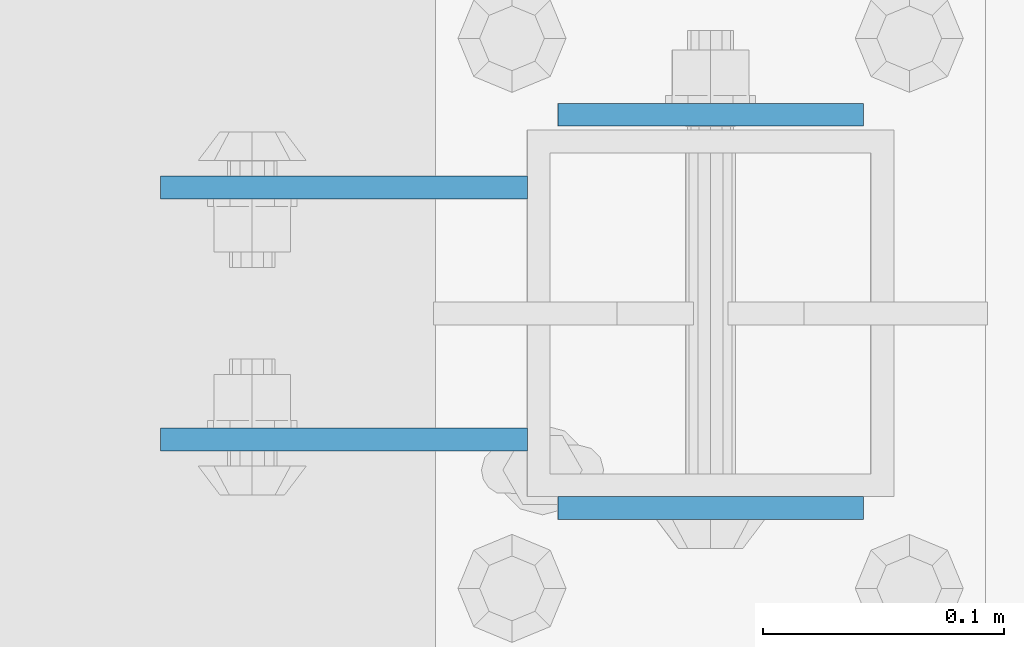
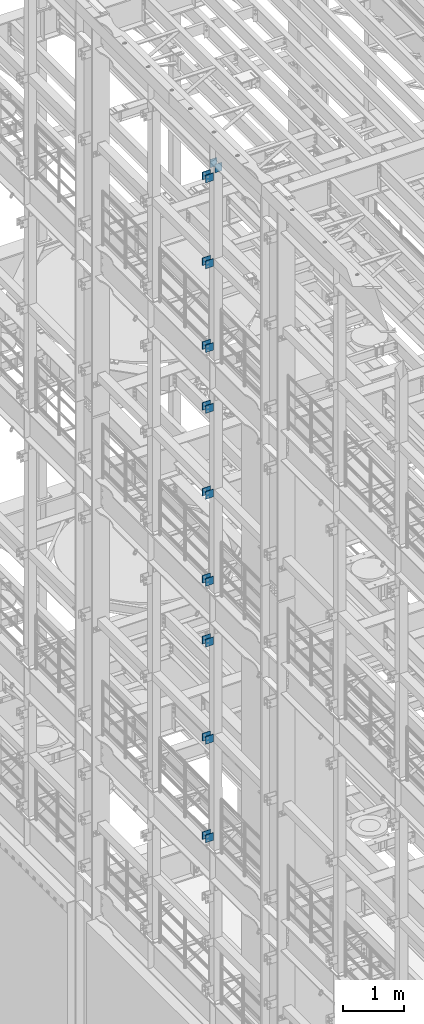
# One storey, part 1248 of 1876: 20 beams, 4 elements without a shape of their own.
"""IFC2X3 building model written with IfcOpenShell, lengths in millimetres."""

from ifc_helpers import new_model, si_unit, frame, origin_with_axes, place, context, subcontext, project, spatial, faceted_brep, material, type_object, element, aggregate, save


model = new_model("IFC2X3")

# Units and contexts
model_context = context("Model", 3, precision=1e-05, world=origin_with_axes())
body_context = subcontext(model_context, "Body", "Model", "MODEL_VIEW")
ifc_project = project(units=[si_unit("LENGTHUNIT", "METRE", prefix="MILLI"), si_unit("AREAUNIT", "SQUARE_METRE"), si_unit("VOLUMEUNIT", "CUBIC_METRE"), si_unit("MASSUNIT", "GRAM", prefix="KILO"), si_unit("TIMEUNIT", "SECOND"), si_unit("PLANEANGLEUNIT", "RADIAN"), si_unit("SOLIDANGLEUNIT", "STERADIAN"), si_unit("THERMODYNAMICTEMPERATUREUNIT", "DEGREE_CELSIUS"), si_unit("LUMINOUSINTENSITYUNIT", "LUMEN")], contexts=[model_context])

# Site, building, storey
site_placement = place(None, origin_with_axes())
site = spatial("IfcSite", under=ifc_project, at=site_placement, CompositionType="ELEMENT")
building_placement = place(site_placement, origin_with_axes())
building = spatial("IfcBuilding", under=site, at=building_placement, Name="Undefined", CompositionType="ELEMENT")
storey_placement = place(building_placement, origin_with_axes())
storey = spatial("IfcBuildingStorey", under=building, at=storey_placement, Name="Undefined", CompositionType="ELEMENT", Elevation=0.0)

# Assembly, beams
assembly_1_placement = place(storey_placement, origin_with_axes())
assembly_1 = element("IfcElementAssembly", 1, at=assembly_1_placement, inside=storey, Name="BEAM", AssemblyPlace="NOTDEFINED", PredefinedType="RIGID_FRAME")
ifc_material = material(Name="STEEL/A36")
beam_type_1 = type_object("IfcBeamType", PredefinedType="NOTDEFINED")
beam_1_placement = place(assembly_1_placement, frame((-76.2000002548894, 3608.3875, 18275.3), z_axis=(0.0, 0.0, -1.0), x_axis=(-1.0, 0.0, 0.0)))
beam_1 = element("IfcBeam", 2, at=beam_1_placement, type_object=beam_type_1, material=ifc_material, Name="PLATE", context=body_context, shape_type="Brep", body=[
    faceted_brep([(0.0, 4.76249999999982, -76.1999999999998), (3.63797880709171e-12, 4.76249999999982, 76.1999969482422), (152.399993896484, 4.76250000000073, 76.1999969482422), (152.4, 4.76249999999982, -76.1999999999998), (3.63797880709171e-12, -4.76249999999982, 76.1999969482422), (152.399993896484, -4.76250000000073, 76.1999969482422), (0.0, -4.76249999999982, -76.1999999999998), (152.4, -4.76249999999982, -76.1999999999998)], [[[0, 1, 2, 3]], [[4, 5, 2, 1]], [[4, 6, 7, 5]], [[6, 0, 3, 7]], [[5, 7, 3, 2]], [[6, 4, 1, 0]]]),
])
beam_2_placement = place(assembly_1_placement, frame((-76.2000002548894, 3503.6125, 18275.3), z_axis=(0.0, 0.0, -1.0), x_axis=(-1.0, 0.0, 0.0)))
beam_2 = element("IfcBeam", 3, at=beam_2_placement, type_object=beam_type_1, material=ifc_material, Name="PLATE", context=body_context, shape_type="Brep", body=[
    faceted_brep([(0.0, 4.76249999999982, -76.1999999999998), (3.63797880709171e-12, 4.76249999999982, 76.1999969482422), (152.399993896484, 4.76250000000073, 76.1999969482422), (152.4, 4.76249999999982, -76.1999999999998), (3.63797880709171e-12, -4.76249999999982, 76.1999969482422), (152.399993896484, -4.76250000000073, 76.1999969482422), (0.0, -4.76249999999982, -76.1999999999998), (152.4, -4.76249999999982, -76.1999999999998)], [[[0, 1, 2, 3]], [[4, 5, 2, 1]], [[4, 6, 7, 5]], [[6, 0, 3, 7]], [[5, 7, 3, 2]], [[6, 4, 1, 0]]]),
])
beam_3_placement = place(assembly_1_placement, frame((-76.2000002548895, 3608.3875, 21678.9), z_axis=(0.0, 0.0, -1.0), x_axis=(-1.0, 0.0, 0.0)))
beam_3 = element("IfcBeam", 4, at=beam_3_placement, type_object=beam_type_1, material=ifc_material, Name="PLATE", context=body_context, shape_type="Brep", body=[
    faceted_brep([(0.0, 4.76249999999982, -76.1999999999998), (3.63797880709171e-12, 4.76249999999982, 76.1999969482422), (152.399993896484, 4.76250000000073, 76.1999969482422), (152.4, 4.76249999999982, -76.1999999999998), (3.63797880709171e-12, -4.76249999999982, 76.1999969482422), (152.399993896484, -4.76250000000073, 76.1999969482422), (0.0, -4.76249999999982, -76.1999999999998), (152.4, -4.76249999999982, -76.1999999999998)], [[[0, 1, 2, 3]], [[4, 5, 2, 1]], [[4, 6, 7, 5]], [[6, 0, 3, 7]], [[5, 7, 3, 2]], [[6, 4, 1, 0]]]),
])
beam_4_placement = place(assembly_1_placement, frame((-76.2000002548895, 3503.6125, 21678.9), z_axis=(0.0, 0.0, -1.0), x_axis=(-1.0, 0.0, 0.0)))
beam_4 = element("IfcBeam", 5, at=beam_4_placement, type_object=beam_type_1, material=ifc_material, Name="PLATE", context=body_context, shape_type="Brep", body=[
    faceted_brep([(0.0, 4.76249999999982, -76.1999999999998), (3.63797880709171e-12, 4.76249999999982, 76.1999969482422), (152.399993896484, 4.76250000000073, 76.1999969482422), (152.4, 4.76249999999982, -76.1999999999998), (3.63797880709171e-12, -4.76249999999982, 76.1999969482422), (152.399993896484, -4.76250000000073, 76.1999969482422), (0.0, -4.76249999999982, -76.1999999999998), (152.4, -4.76249999999982, -76.1999999999998)], [[[0, 1, 2, 3]], [[4, 5, 2, 1]], [[4, 6, 7, 5]], [[6, 0, 3, 7]], [[5, 7, 3, 2]], [[6, 4, 1, 0]]]),
])
beam_5_placement = place(assembly_1_placement, frame((-76.2000002548895, 3608.3875, 19958.05), z_axis=(0.0, 0.0, -1.0), x_axis=(-1.0, 0.0, 0.0)))
beam_5 = element("IfcBeam", 6, at=beam_5_placement, type_object=beam_type_1, material=ifc_material, Name="PLATE", context=body_context, shape_type="Brep", body=[
    faceted_brep([(0.0, 4.76249999999982, -76.1999999999998), (3.63797880709171e-12, 4.76249999999982, 76.1999969482422), (152.399993896484, 4.76250000000073, 76.1999969482422), (152.4, 4.76249999999982, -76.1999999999998), (3.63797880709171e-12, -4.76249999999982, 76.1999969482422), (152.399993896484, -4.76250000000073, 76.1999969482422), (0.0, -4.76249999999982, -76.1999999999998), (152.4, -4.76249999999982, -76.1999999999998)], [[[0, 1, 2, 3]], [[4, 5, 2, 1]], [[4, 6, 7, 5]], [[6, 0, 3, 7]], [[5, 7, 3, 2]], [[6, 4, 1, 0]]]),
])
beam_6_placement = place(assembly_1_placement, frame((-76.2000002548895, 3503.6125, 19958.05), z_axis=(0.0, 0.0, -1.0), x_axis=(-1.0, 0.0, 0.0)))
beam_6 = element("IfcBeam", 7, at=beam_6_placement, type_object=beam_type_1, material=ifc_material, Name="PLATE", context=body_context, shape_type="Brep", body=[
    faceted_brep([(0.0, 4.76249999999982, -76.1999999999998), (3.63797880709171e-12, 4.76249999999982, 76.1999969482422), (152.399993896484, 4.76250000000073, 76.1999969482422), (152.4, 4.76249999999982, -76.1999999999998), (3.63797880709171e-12, -4.76249999999982, 76.1999969482422), (152.399993896484, -4.76250000000073, 76.1999969482422), (0.0, -4.76249999999982, -76.1999999999998), (152.4, -4.76249999999982, -76.1999999999998)], [[[0, 1, 2, 3]], [[4, 5, 2, 1]], [[4, 6, 7, 5]], [[6, 0, 3, 7]], [[5, 7, 3, 2]], [[6, 4, 1, 0]]]),
])
aggregate(assembly_1, [beam_1, beam_2, beam_3, beam_4, beam_5, beam_6])

assembly_2_placement = place(storey_placement, origin_with_axes())
assembly_2 = element("IfcElementAssembly", 8, at=assembly_2_placement, inside=storey, Name="BEAM", AssemblyPlace="NOTDEFINED", PredefinedType="RIGID_FRAME")
beam_7_placement = place(assembly_2_placement, frame((-76.1999999999999, 3608.3875, 13589.0), z_axis=(0.0, 0.0, -1.0), x_axis=(-1.0, 0.0, 0.0)))
beam_7 = element("IfcBeam", 9, at=beam_7_placement, type_object=beam_type_1, material=ifc_material, Name="PLATE", context=body_context, shape_type="Brep", body=[
    faceted_brep([(0.0, 4.76249999999982, -76.1999999999998), (3.63797880709171e-12, 4.76249999999982, 76.1999969482422), (152.399993896484, 4.76250000000073, 76.1999969482422), (152.4, 4.76249999999982, -76.1999999999998), (3.63797880709171e-12, -4.76249999999982, 76.1999969482422), (152.399993896484, -4.76250000000073, 76.1999969482422), (0.0, -4.76249999999982, -76.1999999999998), (152.4, -4.76249999999982, -76.1999999999998)], [[[0, 1, 2, 3]], [[4, 5, 2, 1]], [[4, 6, 7, 5]], [[6, 0, 3, 7]], [[5, 7, 3, 2]], [[6, 4, 1, 0]]]),
])
beam_8_placement = place(assembly_2_placement, frame((-76.1999999999999, 3503.6125, 13589.0), z_axis=(0.0, 0.0, -1.0), x_axis=(-1.0, 0.0, 0.0)))
beam_8 = element("IfcBeam", 10, at=beam_8_placement, type_object=beam_type_1, material=ifc_material, Name="PLATE", context=body_context, shape_type="Brep", body=[
    faceted_brep([(0.0, 4.76249999999982, -76.1999999999998), (3.63797880709171e-12, 4.76249999999982, 76.1999969482422), (152.399993896484, 4.76250000000073, 76.1999969482422), (152.4, 4.76249999999982, -76.1999999999998), (3.63797880709171e-12, -4.76249999999982, 76.1999969482422), (152.399993896484, -4.76250000000073, 76.1999969482422), (0.0, -4.76249999999982, -76.1999999999998), (152.4, -4.76249999999982, -76.1999999999998)], [[[0, 1, 2, 3]], [[4, 5, 2, 1]], [[4, 6, 7, 5]], [[6, 0, 3, 7]], [[5, 7, 3, 2]], [[6, 4, 1, 0]]]),
])
beam_9_placement = place(assembly_2_placement, frame((-76.2, 3608.3875, 17056.1), z_axis=(0.0, 0.0, -1.0), x_axis=(-1.0, 0.0, 0.0)))
beam_9 = element("IfcBeam", 11, at=beam_9_placement, type_object=beam_type_1, material=ifc_material, Name="PLATE", context=body_context, shape_type="Brep", body=[
    faceted_brep([(0.0, 4.76249999999982, -76.1999999999998), (3.63797880709171e-12, 4.76249999999982, 76.1999969482422), (152.399993896484, 4.76250000000073, 76.1999969482422), (152.4, 4.76249999999982, -76.1999999999998), (3.63797880709171e-12, -4.76249999999982, 76.1999969482422), (152.399993896484, -4.76250000000073, 76.1999969482422), (0.0, -4.76249999999982, -76.1999999999998), (152.4, -4.76249999999982, -76.1999999999998)], [[[0, 1, 2, 3]], [[4, 5, 2, 1]], [[4, 6, 7, 5]], [[6, 0, 3, 7]], [[5, 7, 3, 2]], [[6, 4, 1, 0]]]),
])
beam_10_placement = place(assembly_2_placement, frame((-76.2, 3503.6125, 17056.1), z_axis=(0.0, 0.0, -1.0), x_axis=(-1.0, 0.0, 0.0)))
beam_10 = element("IfcBeam", 12, at=beam_10_placement, type_object=beam_type_1, material=ifc_material, Name="PLATE", context=body_context, shape_type="Brep", body=[
    faceted_brep([(0.0, 4.76249999999982, -76.1999999999998), (3.63797880709171e-12, 4.76249999999982, 76.1999969482422), (152.399993896484, 4.76250000000073, 76.1999969482422), (152.4, 4.76249999999982, -76.1999999999998), (3.63797880709171e-12, -4.76249999999982, 76.1999969482422), (152.399993896484, -4.76250000000073, 76.1999969482422), (0.0, -4.76249999999982, -76.1999999999998), (152.4, -4.76249999999982, -76.1999999999998)], [[[0, 1, 2, 3]], [[4, 5, 2, 1]], [[4, 6, 7, 5]], [[6, 0, 3, 7]], [[5, 7, 3, 2]], [[6, 4, 1, 0]]]),
])
beam_11_placement = place(assembly_2_placement, frame((-76.2, 3608.3875, 15335.25), z_axis=(0.0, 0.0, -1.0), x_axis=(-1.0, 0.0, 0.0)))
beam_11 = element("IfcBeam", 13, at=beam_11_placement, type_object=beam_type_1, material=ifc_material, Name="PLATE", context=body_context, shape_type="Brep", body=[
    faceted_brep([(0.0, 4.76249999999982, -76.1999999999998), (3.63797880709171e-12, 4.76249999999982, 76.1999969482422), (152.399993896484, 4.76250000000073, 76.1999969482422), (152.4, 4.76249999999982, -76.1999999999998), (3.63797880709171e-12, -4.76249999999982, 76.1999969482422), (152.399993896484, -4.76250000000073, 76.1999969482422), (0.0, -4.76249999999982, -76.1999999999998), (152.4, -4.76249999999982, -76.1999999999998)], [[[0, 1, 2, 3]], [[4, 5, 2, 1]], [[4, 6, 7, 5]], [[6, 0, 3, 7]], [[5, 7, 3, 2]], [[6, 4, 1, 0]]]),
])
beam_12_placement = place(assembly_2_placement, frame((-76.2, 3503.6125, 15335.25), z_axis=(0.0, 0.0, -1.0), x_axis=(-1.0, 0.0, 0.0)))
beam_12 = element("IfcBeam", 14, at=beam_12_placement, type_object=beam_type_1, material=ifc_material, Name="PLATE", context=body_context, shape_type="Brep", body=[
    faceted_brep([(0.0, 4.76249999999982, -76.1999999999998), (3.63797880709171e-12, 4.76249999999982, 76.1999969482422), (152.399993896484, 4.76250000000073, 76.1999969482422), (152.4, 4.76249999999982, -76.1999999999998), (3.63797880709171e-12, -4.76249999999982, 76.1999969482422), (152.399993896484, -4.76250000000073, 76.1999969482422), (0.0, -4.76249999999982, -76.1999999999998), (152.4, -4.76249999999982, -76.1999999999998)], [[[0, 1, 2, 3]], [[4, 5, 2, 1]], [[4, 6, 7, 5]], [[6, 0, 3, 7]], [[5, 7, 3, 2]], [[6, 4, 1, 0]]]),
])
aggregate(assembly_2, [beam_7, beam_8, beam_9, beam_10, beam_11, beam_12])

assembly_3_placement = place(storey_placement, origin_with_axes())
assembly_3 = element("IfcElementAssembly", 15, at=assembly_3_placement, inside=storey, Name="BEAM", AssemblyPlace="NOTDEFINED", PredefinedType="RIGID_FRAME")
beam_13_placement = place(assembly_3_placement, frame((-76.1999999999999, 3608.3875, 12369.8), z_axis=(0.0, 0.0, -1.0), x_axis=(-1.0, 0.0, 0.0)))
beam_13 = element("IfcBeam", 16, at=beam_13_placement, type_object=beam_type_1, material=ifc_material, Name="PLATE", context=body_context, shape_type="Brep", body=[
    faceted_brep([(0.0, 4.76249999999982, -76.1999999999998), (3.63797880709171e-12, 4.76249999999982, 76.1999969482422), (152.399993896484, 4.76250000000073, 76.1999969482422), (152.4, 4.76249999999982, -76.1999999999998), (3.63797880709171e-12, -4.76249999999982, 76.1999969482422), (152.399993896484, -4.76250000000073, 76.1999969482422), (0.0, -4.76249999999982, -76.1999999999998), (152.4, -4.76249999999982, -76.1999999999998)], [[[0, 1, 2, 3]], [[4, 5, 2, 1]], [[4, 6, 7, 5]], [[6, 0, 3, 7]], [[5, 7, 3, 2]], [[6, 4, 1, 0]]]),
])
beam_14_placement = place(assembly_3_placement, frame((-76.1999999999999, 3503.6125, 12369.8), z_axis=(0.0, 0.0, -1.0), x_axis=(-1.0, 0.0, 0.0)))
beam_14 = element("IfcBeam", 17, at=beam_14_placement, type_object=beam_type_1, material=ifc_material, Name="PLATE", context=body_context, shape_type="Brep", body=[
    faceted_brep([(0.0, 4.76249999999982, -76.1999999999998), (3.63797880709171e-12, 4.76249999999982, 76.1999969482422), (152.399993896484, 4.76250000000073, 76.1999969482422), (152.4, 4.76249999999982, -76.1999999999998), (3.63797880709171e-12, -4.76249999999982, 76.1999969482422), (152.399993896484, -4.76250000000073, 76.1999969482422), (0.0, -4.76249999999982, -76.1999999999998), (152.4, -4.76249999999982, -76.1999999999998)], [[[0, 1, 2, 3]], [[4, 5, 2, 1]], [[4, 6, 7, 5]], [[6, 0, 3, 7]], [[5, 7, 3, 2]], [[6, 4, 1, 0]]]),
])
beam_15_placement = place(assembly_3_placement, frame((-76.2, 3608.3875, 8445.5), z_axis=(0.0, 0.0, -1.0), x_axis=(-1.0, 0.0, 0.0)))
beam_15 = element("IfcBeam", 18, at=beam_15_placement, type_object=beam_type_1, material=ifc_material, Name="PLATE", context=body_context, shape_type="Brep", body=[
    faceted_brep([(0.0, 4.76249999999982, -76.1999999999998), (3.63797880709171e-12, 4.76249999999982, 76.1999969482422), (152.399993896484, 4.76250000000073, 76.1999969482422), (152.4, 4.76249999999982, -76.1999999999998), (3.63797880709171e-12, -4.76249999999982, 76.1999969482422), (152.399993896484, -4.76250000000073, 76.1999969482422), (0.0, -4.76249999999982, -76.1999999999998), (152.4, -4.76249999999982, -76.1999999999998)], [[[0, 1, 2, 3]], [[4, 5, 2, 1]], [[4, 6, 7, 5]], [[6, 0, 3, 7]], [[5, 7, 3, 2]], [[6, 4, 1, 0]]]),
])
beam_16_placement = place(assembly_3_placement, frame((-76.2, 3503.6125, 8445.5), z_axis=(0.0, 0.0, -1.0), x_axis=(-1.0, 0.0, 0.0)))
beam_16 = element("IfcBeam", 19, at=beam_16_placement, type_object=beam_type_1, material=ifc_material, Name="PLATE", context=body_context, shape_type="Brep", body=[
    faceted_brep([(0.0, 4.76249999999982, -76.1999999999998), (3.63797880709171e-12, 4.76249999999982, 76.1999969482422), (152.399993896484, 4.76250000000073, 76.1999969482422), (152.4, 4.76249999999982, -76.1999999999998), (3.63797880709171e-12, -4.76249999999982, 76.1999969482422), (152.399993896484, -4.76250000000073, 76.1999969482422), (0.0, -4.76249999999982, -76.1999999999998), (152.4, -4.76249999999982, -76.1999999999998)], [[[0, 1, 2, 3]], [[4, 5, 2, 1]], [[4, 6, 7, 5]], [[6, 0, 3, 7]], [[5, 7, 3, 2]], [[6, 4, 1, 0]]]),
])
beam_17_placement = place(assembly_3_placement, frame((-76.2, 3608.3875, 10420.35), z_axis=(0.0, 0.0, -1.0), x_axis=(-1.0, 0.0, 0.0)))
beam_17 = element("IfcBeam", 20, at=beam_17_placement, type_object=beam_type_1, material=ifc_material, Name="PLATE", context=body_context, shape_type="Brep", body=[
    faceted_brep([(0.0, 4.76249999999982, -76.1999999999998), (3.63797880709171e-12, 4.76249999999982, 76.1999969482422), (152.399993896484, 4.76250000000073, 76.1999969482422), (152.4, 4.76249999999982, -76.1999999999998), (3.63797880709171e-12, -4.76249999999982, 76.1999969482422), (152.399993896484, -4.76250000000073, 76.1999969482422), (0.0, -4.76249999999982, -76.1999999999998), (152.4, -4.76249999999982, -76.1999999999998)], [[[0, 1, 2, 3]], [[4, 5, 2, 1]], [[4, 6, 7, 5]], [[6, 0, 3, 7]], [[5, 7, 3, 2]], [[6, 4, 1, 0]]]),
])
beam_18_placement = place(assembly_3_placement, frame((-76.2, 3503.6125, 10420.35), z_axis=(0.0, 0.0, -1.0), x_axis=(-1.0, 0.0, 0.0)))
beam_18 = element("IfcBeam", 21, at=beam_18_placement, type_object=beam_type_1, material=ifc_material, Name="PLATE", context=body_context, shape_type="Brep", body=[
    faceted_brep([(0.0, 4.76249999999982, -76.1999999999998), (3.63797880709171e-12, 4.76249999999982, 76.1999969482422), (152.399993896484, 4.76250000000073, 76.1999969482422), (152.4, 4.76249999999982, -76.1999999999998), (3.63797880709171e-12, -4.76249999999982, 76.1999969482422), (152.399993896484, -4.76250000000073, 76.1999969482422), (0.0, -4.76249999999982, -76.1999999999998), (152.4, -4.76249999999982, -76.1999999999998)], [[[0, 1, 2, 3]], [[4, 5, 2, 1]], [[4, 6, 7, 5]], [[6, 0, 3, 7]], [[5, 7, 3, 2]], [[6, 4, 1, 0]]]),
])
aggregate(assembly_3, [beam_13, beam_14, beam_15, beam_16, beam_17, beam_18])

assembly_4_placement = place(storey_placement, origin_with_axes())
assembly_4 = element("IfcElementAssembly", 22, at=assembly_4_placement, inside=storey, Name="BEAM", AssemblyPlace="NOTDEFINED", PredefinedType="RIGID_FRAME")
beam_type_2 = type_object("IfcBeamType", PredefinedType="NOTDEFINED")
beam_19_placement = place(assembly_4_placement, frame((-63.5, 3638.55, 21850.35), z_axis=(0.0, 0.0, -1.0), x_axis=(1.0, 0.0, 0.0)))
beam_19 = element("IfcBeam", 23, at=beam_19_placement, type_object=beam_type_2, material=ifc_material, Name="PLATE", context=body_context, shape_type="Brep", body=[
    faceted_brep([(0.0, 4.76249999999982, -82.5499999999993), (0.0, 4.76249999999982, 82.5499999999993), (127.0, 4.76249999999982, 82.5499999999993), (127.0, 4.76249999999982, -82.5499999999993), (0.0, -4.76249999999982, 82.5499999999993), (127.0, -4.76249999999982, 82.5499999999993), (0.0, -4.76249999999982, -82.5499999999993), (127.0, -4.76249999999982, -82.5499999999993)], [[[0, 1, 2, 3]], [[1, 4, 5, 2]], [[4, 6, 7, 5]], [[6, 0, 3, 7]], [[5, 7, 3, 2]], [[6, 4, 1, 0]]]),
])
beam_20_placement = place(assembly_4_placement, frame((-63.5, 3475.0375, 21850.35), z_axis=(0.0, 0.0, -1.0), x_axis=(1.0, 0.0, 0.0)))
beam_20 = element("IfcBeam", 24, at=beam_20_placement, type_object=beam_type_2, material=ifc_material, Name="PLATE", context=body_context, shape_type="Brep", body=[
    faceted_brep([(0.0, 4.76249999999982, -82.5499999999993), (0.0, 4.76249999999982, 82.5499999999993), (127.0, 4.76249999999982, 82.5499999999993), (127.0, 4.76249999999982, -82.5499999999993), (0.0, -4.76249999999982, 82.5499999999993), (127.0, -4.76249999999982, 82.5499999999993), (0.0, -4.76249999999982, -82.5499999999993), (127.0, -4.76249999999982, -82.5499999999993)], [[[0, 1, 2, 3]], [[1, 4, 5, 2]], [[4, 6, 7, 5]], [[6, 0, 3, 7]], [[5, 7, 3, 2]], [[6, 4, 1, 0]]]),
])
aggregate(assembly_4, [beam_19, beam_20])

save(model, "model.ifc")
